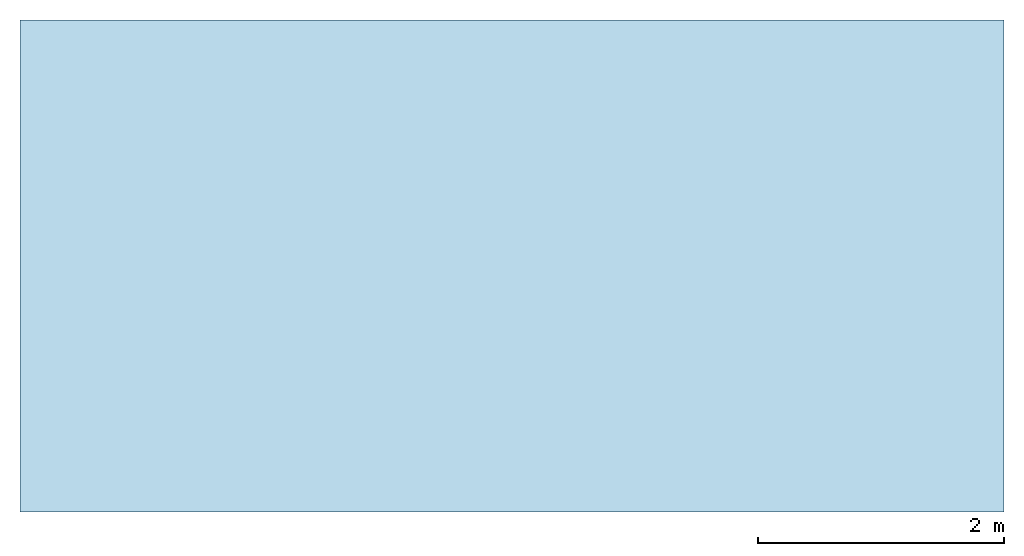
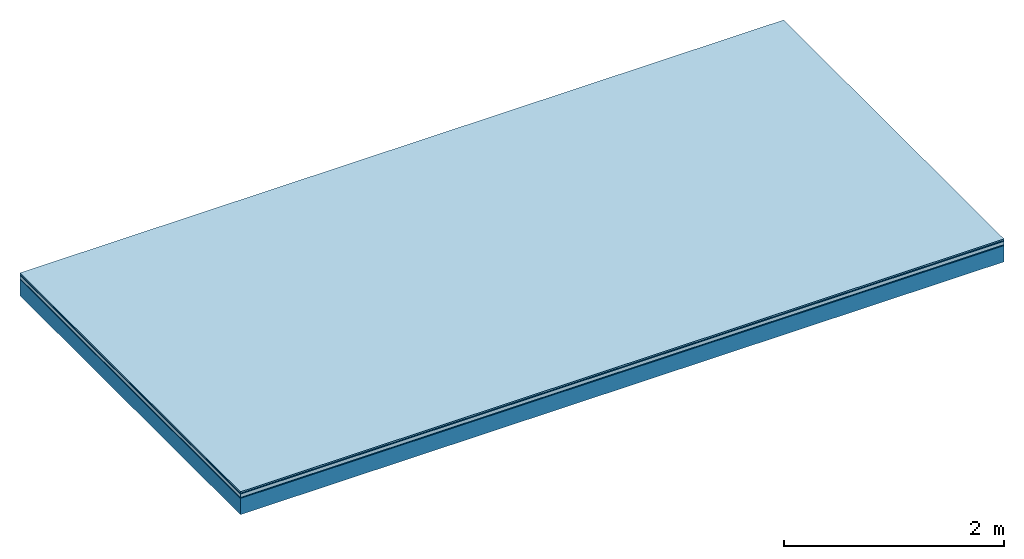
# One storey: 5 plates, 1 member, 1 element without a shape of its own.
"""IFC4 building model written with IfcOpenShell, lengths in metres."""

from ifc_helpers import new_model, si_unit, derived_unit, direction, frame, frame_2d, origin, origin_with_axes, place, context, project, spatial, rectangle, extrude, material, layer, layer_set, type_object, element, aggregate, save


model = new_model("IFC4")

# Units and contexts
plan_context = context("Plan", 3, precision=1e-05, world=origin(), true_north=direction((0.0, 1.0)))
model_context = context("Model", 3, precision=1e-05, world=origin(), true_north=direction((0.0, 1.0)))
ifc_project = project(units=[si_unit("LENGTHUNIT", "METRE"), derived_unit("SOUNDPRESSUREUNIT", [(si_unit("PRESSUREUNIT", "PASCAL", prefix="MICRO"), 0)]), si_unit("ENERGYUNIT", "JOULE", prefix="MEGA"), si_unit("MASSUNIT", "GRAM", prefix="KILO"), derived_unit("THERMALTRANSMITTANCEUNIT", [(si_unit("POWERUNIT", "WATT"), 1), (si_unit("AREAUNIT", "SQUARE_METRE"), -1), (si_unit("THERMODYNAMICTEMPERATUREUNIT", "KELVIN"), -1)]), derived_unit("AREADENSITYUNIT", [(si_unit("MASSUNIT", "GRAM", prefix="KILO"), 1), (si_unit("AREAUNIT", "SQUARE_METRE"), -1)]), derived_unit("USERDEFINED", [(si_unit("ENERGYUNIT", "JOULE", prefix="MEGA"), 1), (si_unit("AREAUNIT", "SQUARE_METRE"), -1)])], contexts=[plan_context, model_context])

# Site, building, storey
site = spatial("IfcSite", under=ifc_project)
building_placement = place(None, origin())
building = spatial("IfcBuilding", under=site, at=building_placement)
storey_placement = place(building_placement, origin())
storey = spatial("IfcBuildingStorey", under=building, at=storey_placement)

# Slab, member, plates
ifc_material_1 = material(Category="11.013")
ifc_layer_1 = layer(ifc_material_1, 0.015, Name="Flooring")
ifc_material_2 = material(Category="03.007")
ifc_layer_2 = layer(ifc_material_2, 0.01, Name="layer")
ifc_material_3 = material(Name="Floor heating system Therm38 standard", Category="03.007")
ifc_layer_3 = layer(ifc_material_3, 0.038, Name="On-material")
ifc_material_4 = material(Name="Wood fiber generic product", Category="10.009")
ifc_layer_4 = layer(ifc_material_4, 0.01, Name="Impact sound insulation")
ifc_material_5 = material(Name="protection", Category="09.007")
ifc_layer_5 = layer(ifc_material_5, 0.0005, Name="Sub-floor")
ifc_material_6 = material(Name="no composite action")
ifc_layer_6 = layer(ifc_material_6, 0.0, Name="Bond")
ifc_layer_7 = layer(None, 0.18, Name="Supporting structure")
ifc_layer_set = layer_set([ifc_layer_1, ifc_layer_2, ifc_layer_3, ifc_layer_4, ifc_layer_5, ifc_layer_6, ifc_layer_7])
slab_type = type_object("IfcSlabType", Name="A2036", PredefinedType="NOTDEFINED", material=ifc_layer_set)
slab_placement = place(None, frame((0.0, 0.0, 0.0), z_axis=(0.0, 0.0, -1.0), x_axis=(1.0, 0.0, 0.0)))
slab = element("IfcSlab", 1, at=slab_placement, inside=storey, type_object=slab_type, material=ifc_layer_set, Name="Slab #1")
ifc_material_7 = material(Name="Solid timber panel")
member_placement = place(slab_placement, origin())
member = element("IfcMember", 2, at=member_placement, material=ifc_material_7, Name="Supporting structure", context=plan_context, shape_type="SweptSolid", body=[
    extrude(rectangle(XDim=1.0, YDim=0.18, at=frame_2d((0.5, 0.09), x_axis=(1.0, 0.0))), frame((0.0, 4.0, 0.0735), z_axis=(0.0, -1.0, 0.0), x_axis=(1.0, 0.0, 0.0)), (0.0, 0.0, 1.0), 4.0),
    extrude(rectangle(XDim=1.0, YDim=0.18, at=frame_2d((0.5, 0.09), x_axis=(1.0, 0.0))), frame((1.0, 4.0, 0.0735), z_axis=(0.0, -1.0, 0.0), x_axis=(1.0, 0.0, 0.0)), (0.0, 0.0, 1.0), 4.0),
    extrude(rectangle(XDim=1.0, YDim=0.18, at=frame_2d((0.5, 0.09), x_axis=(1.0, 0.0))), frame((2.0, 4.0, 0.0735), z_axis=(0.0, -1.0, 0.0), x_axis=(1.0, 0.0, 0.0)), (0.0, 0.0, 1.0), 4.0),
    extrude(rectangle(XDim=1.0, YDim=0.18, at=frame_2d((0.5, 0.09), x_axis=(1.0, 0.0))), frame((3.0, 4.0, 0.0735), z_axis=(0.0, -1.0, 0.0), x_axis=(1.0, 0.0, 0.0)), (0.0, 0.0, 1.0), 4.0),
    extrude(rectangle(XDim=1.0, YDim=0.18, at=frame_2d((0.5, 0.09), x_axis=(1.0, 0.0))), frame((4.0, 4.0, 0.0735), z_axis=(0.0, -1.0, 0.0), x_axis=(1.0, 0.0, 0.0)), (0.0, 0.0, 1.0), 4.0),
    extrude(rectangle(XDim=1.0, YDim=0.18, at=frame_2d((0.5, 0.09), x_axis=(1.0, 0.0))), frame((5.0, 4.0, 0.0735), z_axis=(0.0, -1.0, 0.0), x_axis=(1.0, 0.0, 0.0)), (0.0, 0.0, 1.0), 4.0),
    extrude(rectangle(XDim=1.0, YDim=0.18, at=frame_2d((0.5, 0.09), x_axis=(1.0, 0.0))), frame((6.0, 4.0, 0.0735), z_axis=(0.0, -1.0, 0.0), x_axis=(1.0, 0.0, 0.0)), (0.0, 0.0, 1.0), 4.0),
    extrude(rectangle(XDim=1.0, YDim=0.18, at=frame_2d((0.5, 0.09), x_axis=(1.0, 0.0))), frame((7.0, 4.0, 0.0735), z_axis=(0.0, -1.0, 0.0), x_axis=(1.0, 0.0, 0.0)), (0.0, 0.0, 1.0), 4.0),
])
plate_1_placement = place(slab_placement, origin())
plate_1 = element("IfcPlate", 3, at=plate_1_placement, material=ifc_material_1, Name="Flooring", context=plan_context, shape_type="SweptSolid", body=[
    extrude(rectangle(XDim=8.0, YDim=4.0, at=frame_2d((4.0, 2.0), x_axis=(1.0, 0.0))), origin_with_axes(), (0.0, 0.0, 1.0), 0.015),
])
plate_2_placement = place(slab_placement, origin())
plate_2 = element("IfcPlate", 4, at=plate_2_placement, material=ifc_material_2, Name="layer", context=plan_context, shape_type="SweptSolid", body=[
    extrude(rectangle(XDim=8.0, YDim=4.0, at=frame_2d((4.0, 2.0), x_axis=(1.0, 0.0))), frame((0.0, 0.0, 0.015), z_axis=(0.0, 0.0, 1.0), x_axis=(1.0, 0.0, 0.0)), (0.0, 0.0, 1.0), 0.01),
])
plate_3_placement = place(slab_placement, origin())
plate_3 = element("IfcPlate", 5, at=plate_3_placement, material=ifc_material_3, Name="On-material", context=plan_context, shape_type="SweptSolid", body=[
    extrude(rectangle(XDim=8.0, YDim=4.0, at=frame_2d((4.0, 2.0), x_axis=(1.0, 0.0))), frame((0.0, 0.0, 0.025), z_axis=(0.0, 0.0, 1.0), x_axis=(1.0, 0.0, 0.0)), (0.0, 0.0, 1.0), 0.038),
])
plate_4_placement = place(slab_placement, origin())
plate_4 = element("IfcPlate", 6, at=plate_4_placement, material=ifc_material_4, Name="Impact sound insulation", context=plan_context, shape_type="SweptSolid", body=[
    extrude(rectangle(XDim=8.0, YDim=4.0, at=frame_2d((4.0, 2.0), x_axis=(1.0, 0.0))), frame((0.0, 0.0, 0.063), z_axis=(0.0, 0.0, 1.0), x_axis=(1.0, 0.0, 0.0)), (0.0, 0.0, 1.0), 0.01),
])
plate_5_placement = place(slab_placement, origin())
plate_5 = element("IfcPlate", 7, at=plate_5_placement, material=ifc_material_5, Name="Sub-floor", context=plan_context, shape_type="SweptSolid", body=[
    extrude(rectangle(XDim=8.0, YDim=4.0, at=frame_2d((4.0, 2.0), x_axis=(1.0, 0.0))), frame((0.0, 0.0, 0.073), z_axis=(0.0, 0.0, 1.0), x_axis=(1.0, 0.0, 0.0)), (0.0, 0.0, 1.0), 0.0005),
])
aggregate(slab, [plate_1, plate_2, plate_3, plate_4, plate_5, member])

save(model, "model.ifc")
